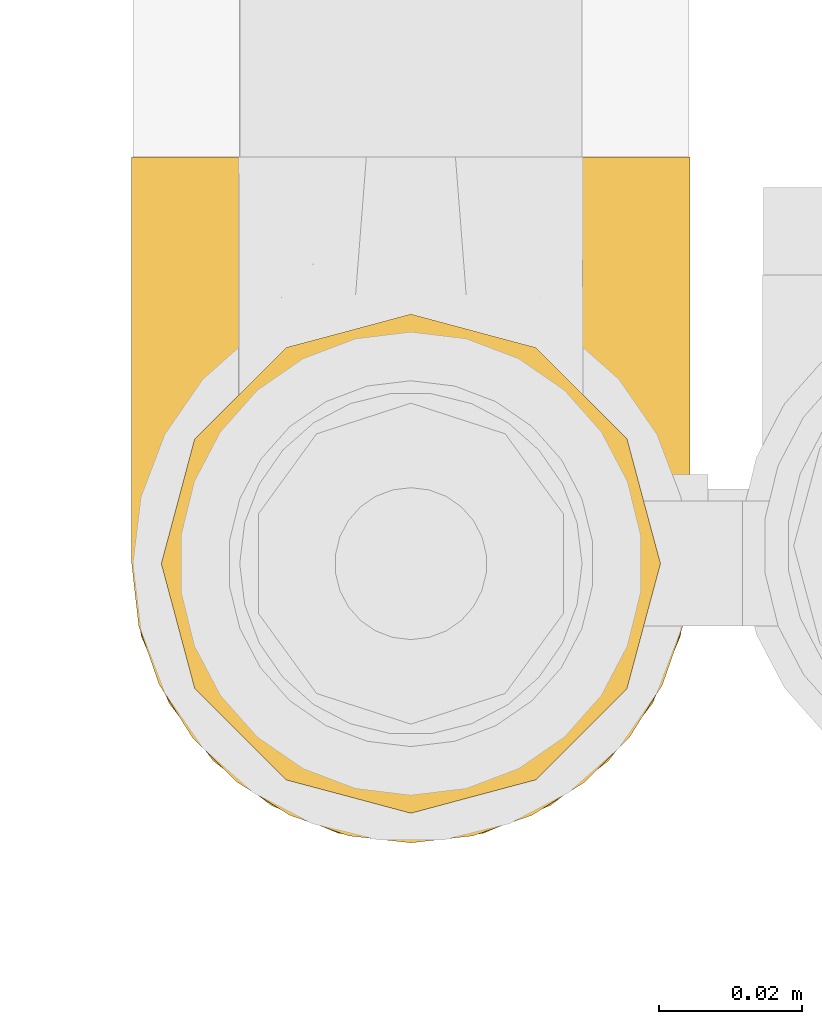
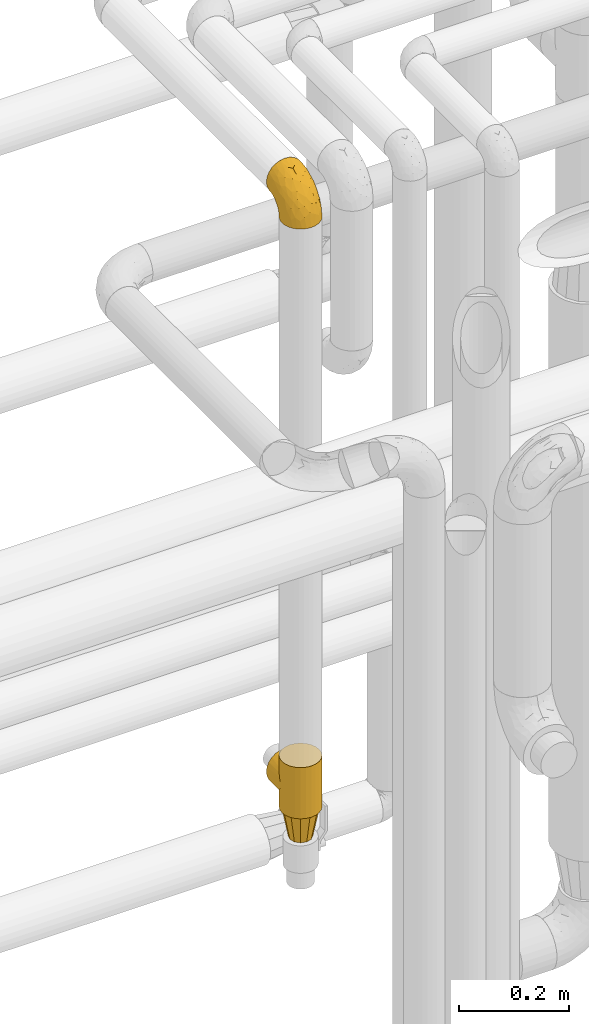
# One storey, part 428 of 827: 3 coverings.
"""IFC2X3 building model written with IfcOpenShell, lengths in millimetres."""

from ifc_helpers import new_model, entity, si_unit, converted_unit, derived_unit, direction, frame, origin, place, context, subcontext, project, spatial, faceted_brep, element, save


model = new_model("IFC2X3")

# Units and contexts
model_context = context("Model", 3, precision=0.01, world=origin(), true_north=direction((6.12303176911189e-17, 1.0)))
body_context = subcontext(model_context, "Body", "Model", "MODEL_VIEW")
ifc_project = project(units=[si_unit("LENGTHUNIT", "METRE", prefix="MILLI"), si_unit("AREAUNIT", "SQUARE_METRE"), si_unit("VOLUMEUNIT", "CUBIC_METRE"), converted_unit("PLANEANGLEUNIT", "DEGREE", entity("IfcRatioMeasure", 0.0174532925199433), si_unit("PLANEANGLEUNIT", "RADIAN"), dimensions=[0, 0, 0, 0, 0, 0, 0]), si_unit("MASSUNIT", "GRAM", prefix="KILO"), derived_unit("MASSDENSITYUNIT", [(si_unit("MASSUNIT", "GRAM", prefix="KILO"), 1), (si_unit("LENGTHUNIT", "METRE"), -3)]), derived_unit("MOMENTOFINERTIAUNIT", [(si_unit("LENGTHUNIT", "METRE"), 4)]), si_unit("TIMEUNIT", "SECOND"), si_unit("FREQUENCYUNIT", "HERTZ"), si_unit("THERMODYNAMICTEMPERATUREUNIT", "DEGREE_CELSIUS"), derived_unit("THERMALTRANSMITTANCEUNIT", [(si_unit("MASSUNIT", "GRAM", prefix="KILO"), 1), (si_unit("THERMODYNAMICTEMPERATUREUNIT", "KELVIN"), -1), (si_unit("TIMEUNIT", "SECOND"), -3)]), derived_unit("VOLUMETRICFLOWRATEUNIT", [(si_unit("LENGTHUNIT", "METRE"), 3), (si_unit("TIMEUNIT", "SECOND"), -1)]), derived_unit("MASSFLOWRATEUNIT", [(si_unit("MASSUNIT", "GRAM", prefix="KILO"), 1), (si_unit("TIMEUNIT", "SECOND"), -1)]), derived_unit("ROTATIONALFREQUENCYUNIT", [(si_unit("TIMEUNIT", "SECOND"), -1)]), si_unit("ELECTRICCURRENTUNIT", "AMPERE"), si_unit("ELECTRICVOLTAGEUNIT", "VOLT"), si_unit("POWERUNIT", "WATT"), si_unit("FORCEUNIT", "NEWTON", prefix="KILO"), si_unit("ILLUMINANCEUNIT", "LUX"), si_unit("LUMINOUSFLUXUNIT", "LUMEN"), si_unit("LUMINOUSINTENSITYUNIT", "CANDELA"), derived_unit("USERDEFINED", [(si_unit("MASSUNIT", "GRAM", prefix="KILO"), -1), (si_unit("LENGTHUNIT", "METRE"), -2), (si_unit("TIMEUNIT", "SECOND"), 3), (si_unit("LUMINOUSFLUXUNIT", "LUMEN"), 1)]), derived_unit("LINEARVELOCITYUNIT", [(si_unit("LENGTHUNIT", "METRE"), 1), (si_unit("TIMEUNIT", "SECOND"), -1)]), si_unit("PRESSUREUNIT", "PASCAL"), derived_unit("USERDEFINED", [(si_unit("LENGTHUNIT", "METRE"), -2), (si_unit("MASSUNIT", "GRAM", prefix="KILO"), 1), (si_unit("TIMEUNIT", "SECOND"), -2)]), derived_unit("LINEARFORCEUNIT", [(si_unit("MASSUNIT", "GRAM", prefix="KILO"), 1), (si_unit("LENGTHUNIT", "METRE"), 1), (si_unit("TIMEUNIT", "SECOND"), -2), (si_unit("LENGTHUNIT", "METRE"), -1)]), derived_unit("PLANARFORCEUNIT", [(si_unit("MASSUNIT", "GRAM", prefix="KILO"), 1), (si_unit("LENGTHUNIT", "METRE"), 1), (si_unit("TIMEUNIT", "SECOND"), -2), (si_unit("LENGTHUNIT", "METRE"), -2)])], contexts=[model_context])

# Site, building, storey
site_placement = place(None, origin())
site = spatial("IfcSite", under=ifc_project, at=site_placement, CompositionType="ELEMENT")
building_placement = place(site_placement, origin())
building = spatial("IfcBuilding", under=site, at=building_placement, CompositionType="ELEMENT")
storey_placement = place(building_placement, frame((0.0, 0.0, 28200.0)))
storey = spatial("IfcBuildingStorey", under=building, at=storey_placement, Name="08", CompositionType="ELEMENT", Elevation=28200.0)

# Coverings
covering_1_placement = place(storey_placement, frame((55693.43, 16227.19, 3141.4)))
element("IfcCovering", 1, at=covering_1_placement, inside=storey, Name=":ADSK_", ObjectType=":ADSK_", PredefinedType="INSULATION", context=body_context, shape_type="Brep", body=[
    faceted_brep([(79.9, 40.75, 1.6), (78.91, 32.03, 1.6), (76.02, 23.75, 1.6), (71.35, 16.33, 1.6), (65.15, 10.13, 1.6), (57.73, 5.47, 1.6), (49.45, 2.58, 1.6), (40.75, 1.6, 1.6), (32.03, 2.58, 1.6), (23.75, 5.48, 1.6), (16.33, 10.14, 1.6), (10.13, 16.34, 1.6), (5.47, 23.76, 1.6), (2.58, 32.04, 1.6), (1.6, 40.75, 1.6), (1.96, 43.94, 1.6), (2.58, 49.46, 1.6), (4.03, 53.6, 1.6), (5.48, 57.74, 1.6), (10.14, 65.16, 1.6), (16.34, 71.36, 1.6), (23.76, 76.02, 1.6), (32.04, 78.91, 1.6), (40.75, 79.9, 1.6), (49.46, 78.91, 1.6), (57.74, 76.02, 1.6), (65.16, 71.35, 1.6), (71.36, 65.15, 1.6), (76.02, 57.73, 1.6), (78.91, 49.45, 1.6), (79.54, 43.94, 1.6), (13.06, 97.75, 30.91), (6.84, 97.75, 39.02), (2.93, 97.75, 48.46), (2.44, 97.75, 52.18), (2.02, 97.75, 55.39), (1.6, 97.75, 58.6), (2.93, 97.75, 68.73), (6.84, 97.75, 78.17), (13.06, 97.75, 86.28), (21.17, 97.75, 92.5), (30.61, 97.75, 96.41), (40.75, 97.75, 97.75), (50.88, 97.75, 96.41), (60.32, 97.75, 92.5), (68.43, 97.75, 86.28), (74.65, 97.75, 78.17), (78.56, 97.75, 68.73), (79.9, 97.75, 58.6), (79.05, 97.75, 52.18), (78.56, 97.75, 48.46), (74.65, 97.75, 39.02), (68.43, 97.75, 30.91), (60.32, 97.75, 24.69), (50.88, 97.75, 20.78), (40.75, 97.75, 19.45), (30.61, 97.75, 20.78), (21.17, 97.75, 24.69), (40.75, 30.59, 68.75), (40.75, 19.96, 58.11), (53.99, 31.39, 67.95), (40.75, 41.23, 79.38), (40.75, 68.03, 93.04), (47.49, 73.86, 94.13), (40.75, 78.49, 94.7), (51.52, 51.06, 83.92), (61.86, 61.05, 83.74), (54.43, 74.96, 92.46), (63.37, 80.64, 88.89), (79.25, 35.94, 18.55), (77.04, 55.44, 59.47), (75.79, 78.19, 73.43), (72.61, 58.08, 70.77), (78.93, 78.4, 64.34), (70.12, 74.65, 81.19), (66.7, 14.61, 24.77), (72.7, 20.05, 18.96), (70.21, 24.25, 39.69), (78.8, 43.81, 39.98), (79.9, 45.08, 23.41), (79.9, 48.17, 28.03), (79.9, 51.26, 32.65), (79.9, 54.35, 37.28), (79.9, 57.44, 41.9), (74.44, 40.25, 52.71), (52.47, 6.22, 24.51), (79.33, 61.23, 53.67), (79.9, 62.06, 44.99), (79.9, 66.69, 48.08), (79.9, 71.31, 51.17), (79.9, 75.93, 54.26), (48.94, 13.08, 45.31), (58.78, 14.98, 41.19), (60.43, 8.5, 18.54), (40.75, 4.64, 20.85), (62.02, 36.67, 67.52), (57.53, 22.97, 55.82), (79.9, 41.46, 5.17), (79.9, 42.17, 8.74), (79.9, 43.59, 15.88), (64.12, 25.24, 52.18), (75.76, 31.25, 35.23), (76.65, 26.96, 17.8), (68.92, 38.0, 60.91), (66.73, 50.65, 73.89), (40.75, 54.63, 86.21), (40.75, 6.3, 31.31), (79.9, 83.46, 55.75), (79.9, 87.03, 56.46), (79.9, 90.6, 57.17), (40.75, 13.13, 44.71), (63.86, 91.79, 26.29), (69.15, 87.2, 29.74), (78.65, 87.5, 47.68), (72.98, 89.79, 35.46), (76.47, 88.45, 41.52), (76.82, 81.77, 40.21), (79.05, 79.81, 47.09), (79.09, 73.84, 44.48), (51.28, 91.84, 19.96), (51.03, 86.62, 17.27), (40.75, 85.12, 14.22), (40.75, 91.15, 16.71), (49.93, 80.84, 10.14), (58.53, 78.96, 13.28), (69.86, 71.38, 17.56), (65.19, 76.81, 17.71), (70.75, 74.29, 23.15), (79.25, 48.29, 8.48), (79.11, 49.97, 13.45), (57.89, 92.85, 22.84), (55.93, 77.55, 7.02), (78.06, 62.05, 29.23), (75.39, 70.85, 29.51), (78.16, 65.52, 33.67), (66.62, 80.71, 23.34), (73.14, 77.97, 30.5), (71.07, 66.14, 7.97), (78.32, 57.01, 22.97), (73.93, 64.57, 16.17), (77.25, 56.53, 13.36), (79.26, 51.07, 19.39), (60.3, 81.85, 18.33), (40.75, 82.63, 8.19), (65.72, 72.53, 10.82), (74.5, 67.69, 23.48), (60.62, 86.44, 21.93), (73.96, 82.44, 34.48), (77.3, 75.97, 38.65), (77.83, 70.39, 36.64), (23.6, 92.85, 22.84), (17.57, 88.99, 25.49), (1.6, 41.46, 5.17), (1.6, 42.17, 8.74), (1.6, 43.59, 15.88), (31.57, 80.84, 10.14), (22.97, 78.97, 13.28), (25.57, 77.55, 7.02), (15.78, 72.54, 10.82), (1.6, 83.46, 55.75), (1.6, 90.6, 57.17), (1.6, 94.17, 57.88), (12.34, 87.2, 29.74), (7.57, 82.6, 34.5), (8.85, 89.34, 34.84), (2.63, 80.74, 46.53), (4.67, 81.77, 40.21), (2.36, 74.04, 44.84), (1.6, 75.93, 54.26), (2.84, 87.5, 47.68), (2.24, 51.07, 19.39), (1.6, 48.17, 28.03), (3.18, 57.03, 22.96), (10.74, 74.31, 23.16), (15.18, 80.61, 22.9), (16.42, 77.09, 17.91), (30.21, 91.84, 19.96), (9.98, 79.19, 28.63), (30.46, 86.62, 17.27), (10.43, 66.15, 7.97), (12.05, 71.84, 17.45), (4.24, 56.55, 13.36), (7.56, 64.59, 16.17), (3.43, 62.05, 29.23), (2.38, 49.99, 13.44), (1.6, 45.08, 23.41), (3.66, 70.39, 36.64), (4.45, 76.36, 38.11), (6.98, 67.71, 23.51), (6.12, 70.92, 29.52), (5.38, 89.33, 40.9), (21.58, 82.04, 18.21), (1.6, 51.26, 32.65), (20.87, 86.44, 21.93), (3.35, 65.56, 33.63), (1.6, 62.06, 44.99), (1.6, 57.44, 41.9), (1.6, 54.35, 37.28), (1.6, 71.31, 51.17), (1.6, 66.69, 48.08), (2.16, 61.23, 53.67), (11.37, 74.65, 81.19), (5.7, 78.19, 73.43), (8.88, 58.07, 70.76), (12.57, 38.01, 60.91), (7.04, 40.25, 52.7), (11.27, 24.26, 39.68), (17.36, 25.25, 52.18), (2.69, 43.81, 39.98), (2.56, 78.4, 64.34), (34.0, 73.86, 94.13), (27.06, 74.96, 92.46), (4.45, 55.45, 59.46), (5.73, 31.26, 35.22), (18.12, 80.64, 88.89), (19.63, 61.05, 83.74), (27.49, 31.39, 67.95), (19.46, 36.69, 67.52), (2.24, 35.95, 18.55), (29.01, 6.22, 24.51), (14.78, 14.62, 24.77), (32.55, 13.09, 45.32), (8.78, 20.06, 18.96), (29.98, 51.06, 83.92), (23.95, 22.97, 55.82), (22.7, 14.99, 41.19), (21.05, 8.51, 18.54), (14.75, 50.64, 73.87), (4.84, 26.97, 17.8)], [[[0, 1, 2, 3, 4, 5, 6, 7, 8, 9, 10, 11, 12, 13, 14, 15, 16, 17, 18, 19, 20, 21, 22, 23, 24, 25, 26, 27, 28, 29, 30]], [[31, 32, 33, 34, 35, 36, 37, 38, 39, 40, 41, 42, 43, 44, 45, 46, 47, 48, 49, 50, 51, 52, 53, 54, 55, 56, 57]], [[58, 59, 60, 61]], [[62, 63, 64]], [[65, 66, 67]], [[67, 66, 68]], [[69, 1, 0]], [[70, 71, 72]], [[44, 43, 67]], [[47, 71, 73]], [[45, 74, 46]], [[68, 45, 44]], [[75, 76, 77]], [[76, 3, 2]], [[78, 79, 80, 81, 82, 83]], [[48, 47, 73]], [[70, 72, 84]], [[5, 85, 6]], [[86, 83, 87, 88, 89, 90]], [[91, 85, 92]], [[76, 75, 3]], [[71, 46, 74]], [[85, 5, 93]], [[45, 68, 74]], [[5, 4, 93]], [[85, 94, 6]], [[86, 78, 83]], [[60, 95, 65]], [[96, 95, 60]], [[75, 4, 3]], [[69, 0, 97, 98, 99, 79]], [[75, 77, 100]], [[43, 64, 63]], [[101, 102, 69]], [[101, 76, 102]], [[46, 71, 47]], [[95, 103, 104]], [[92, 85, 93]], [[63, 105, 65]], [[92, 75, 100]], [[91, 106, 85]], [[84, 78, 70]], [[67, 68, 44]], [[65, 67, 63]], [[65, 61, 60]], [[4, 75, 93]], [[92, 93, 75]], [[102, 76, 2]], [[77, 76, 101]], [[84, 77, 101]], [[77, 103, 100]], [[72, 71, 74]], [[70, 86, 73]], [[104, 74, 66]], [[84, 72, 103]], [[70, 73, 71]], [[73, 90, 107, 108, 109, 48]], [[79, 78, 69]], [[101, 69, 78]], [[91, 92, 96]], [[91, 59, 110, 106]], [[2, 1, 102]], [[69, 102, 1]], [[94, 85, 106]], [[94, 7, 6]], [[74, 68, 66]], [[43, 42, 64]], [[43, 63, 67]], [[73, 86, 90]], [[78, 86, 70]], [[95, 100, 103]], [[96, 92, 100]], [[104, 103, 72]], [[65, 95, 66]], [[74, 104, 72]], [[66, 95, 104]], [[95, 96, 100]], [[91, 96, 60]], [[77, 84, 103]], [[78, 84, 101]], [[60, 59, 91]], [[105, 63, 62]], [[105, 61, 65]], [[111, 52, 112]], [[107, 90, 113]], [[114, 115, 116]], [[50, 107, 113]], [[117, 118, 116]], [[54, 119, 55]], [[97, 0, 30, 29, 98]], [[113, 115, 51]], [[120, 121, 122]], [[123, 120, 124]], [[125, 126, 127]], [[128, 28, 129]], [[130, 54, 53]], [[25, 24, 131]], [[132, 133, 134]], [[135, 112, 136]], [[137, 27, 26]], [[121, 120, 123]], [[138, 139, 132]], [[129, 140, 141]], [[135, 126, 142]], [[27, 140, 28]], [[27, 137, 140]], [[49, 48, 109, 108, 107, 50]], [[23, 143, 121, 123]], [[25, 131, 144]], [[26, 25, 144]], [[128, 98, 29]], [[125, 127, 145]], [[146, 130, 111]], [[137, 144, 139]], [[139, 138, 140]], [[116, 147, 114]], [[123, 124, 131]], [[116, 118, 148]], [[134, 83, 82]], [[129, 79, 99]], [[54, 130, 119]], [[141, 79, 129]], [[122, 55, 119]], [[120, 146, 142]], [[117, 113, 90]], [[50, 113, 51]], [[127, 133, 145]], [[147, 136, 112]], [[136, 133, 127]], [[24, 23, 123]], [[118, 117, 89]], [[149, 87, 134]], [[144, 131, 124]], [[24, 123, 131]], [[128, 129, 99]], [[28, 140, 129]], [[144, 137, 26]], [[140, 137, 139]], [[81, 138, 132]], [[138, 80, 141]], [[89, 88, 87, 118]], [[115, 117, 116]], [[140, 138, 141]], [[148, 118, 149]], [[136, 148, 149]], [[147, 116, 148]], [[133, 136, 149]], [[127, 126, 135]], [[136, 147, 148]], [[114, 112, 52]], [[112, 114, 147]], [[51, 114, 52]], [[51, 115, 114]], [[117, 115, 113]], [[117, 90, 89]], [[134, 133, 149]], [[145, 133, 132]], [[132, 139, 145]], [[125, 139, 144]], [[139, 125, 145]], [[126, 144, 124]], [[144, 126, 125]], [[142, 126, 124]], [[120, 142, 124]], [[142, 146, 135]], [[112, 135, 146]], [[136, 127, 135]], [[118, 87, 149]], [[82, 81, 132]], [[111, 130, 53]], [[119, 146, 120]], [[146, 119, 130]], [[122, 119, 120]], [[52, 111, 53]], [[146, 111, 112]], [[134, 82, 132]], [[83, 134, 87]], [[98, 128, 99]], [[80, 138, 81]], [[80, 79, 141]], [[28, 128, 29]], [[150, 151, 57]], [[15, 14, 152, 153, 154, 16]], [[121, 143, 23, 155]], [[150, 57, 56]], [[156, 157, 158]], [[35, 34, 33, 159, 160, 161, 36]], [[162, 31, 57]], [[163, 164, 162]], [[165, 166, 167]], [[155, 23, 22]], [[168, 159, 169]], [[170, 171, 172]], [[173, 174, 175]], [[55, 122, 176]], [[177, 174, 173]], [[22, 157, 155]], [[178, 121, 155]], [[169, 33, 32]], [[20, 19, 179]], [[21, 20, 158]], [[158, 180, 175]], [[181, 182, 179]], [[172, 183, 182]], [[122, 121, 178]], [[181, 19, 18]], [[184, 185, 170]], [[17, 154, 184]], [[186, 187, 177]], [[187, 186, 167]], [[179, 158, 20]], [[21, 157, 22]], [[175, 180, 173]], [[188, 189, 173]], [[164, 166, 190]], [[185, 184, 154]], [[181, 172, 182]], [[156, 191, 178]], [[192, 183, 172]], [[178, 176, 122]], [[193, 150, 176]], [[33, 169, 159]], [[190, 169, 32]], [[189, 194, 186]], [[180, 188, 173]], [[167, 166, 187]], [[166, 164, 163]], [[195, 194, 196]], [[158, 157, 21]], [[155, 157, 156]], [[178, 155, 156]], [[181, 18, 184]], [[17, 16, 154]], [[181, 179, 19]], [[158, 179, 182]], [[170, 181, 184]], [[196, 194, 197]], [[31, 190, 32]], [[165, 190, 166]], [[190, 31, 164]], [[31, 162, 164]], [[177, 163, 162]], [[187, 166, 163]], [[151, 174, 177]], [[177, 173, 189]], [[177, 187, 163]], [[195, 167, 186]], [[165, 198, 168]], [[165, 168, 169]], [[167, 198, 165]], [[190, 165, 169]], [[167, 195, 199, 198]], [[151, 177, 162]], [[175, 191, 156]], [[191, 174, 193]], [[158, 175, 156]], [[174, 191, 175]], [[178, 191, 193]], [[158, 182, 180]], [[188, 182, 183]], [[182, 188, 180]], [[183, 194, 189]], [[183, 189, 188]], [[177, 189, 186]], [[194, 183, 197]], [[176, 150, 56]], [[151, 150, 193]], [[176, 56, 55]], [[193, 176, 178]], [[174, 151, 193]], [[57, 151, 162]], [[183, 192, 197]], [[194, 195, 186]], [[171, 192, 172]], [[172, 181, 170]], [[170, 185, 171]], [[184, 18, 17]], [[200, 168, 198, 199, 195, 196]], [[201, 202, 203]], [[204, 203, 205]], [[204, 206, 207]], [[208, 196, 197, 192, 171, 185]], [[209, 36, 161, 160, 159, 168]], [[202, 38, 37]], [[201, 38, 202]], [[210, 41, 211]], [[200, 208, 212]], [[205, 208, 213]], [[214, 211, 40]], [[40, 211, 41]], [[214, 201, 215]], [[58, 61, 216, 59]], [[201, 39, 38]], [[207, 217, 204]], [[213, 208, 218]], [[218, 185, 154, 153, 152, 14]], [[14, 13, 218]], [[9, 8, 219]], [[10, 220, 11]], [[221, 106, 110, 59]], [[219, 8, 94]], [[220, 222, 11]], [[223, 211, 215]], [[221, 216, 224]], [[225, 219, 221]], [[10, 9, 226]], [[213, 222, 206]], [[226, 9, 219]], [[106, 219, 94]], [[212, 202, 209]], [[201, 203, 227]], [[226, 225, 220]], [[207, 206, 220]], [[214, 40, 39]], [[11, 222, 12]], [[12, 222, 228]], [[41, 210, 64]], [[223, 105, 210]], [[223, 215, 217]], [[105, 62, 210]], [[206, 222, 220]], [[228, 222, 213]], [[207, 220, 225]], [[205, 206, 204]], [[225, 226, 219]], [[220, 10, 226]], [[209, 202, 37]], [[203, 202, 212]], [[205, 203, 212]], [[204, 217, 227]], [[36, 209, 37]], [[209, 168, 200]], [[218, 13, 228]], [[208, 185, 218]], [[106, 221, 219]], [[221, 59, 216]], [[218, 228, 213]], [[13, 12, 228]], [[8, 7, 94]], [[201, 214, 39]], [[211, 214, 215]], [[64, 210, 62]], [[64, 42, 41]], [[223, 210, 211]], [[208, 200, 196]], [[209, 200, 212]], [[225, 224, 207]], [[207, 224, 217]], [[223, 217, 216]], [[204, 227, 203]], [[217, 215, 227]], [[201, 227, 215]], [[221, 224, 225]], [[217, 224, 216]], [[208, 205, 212]], [[206, 205, 213]], [[216, 61, 223]], [[223, 61, 105]]]),
])
covering_2_placement = place(storey_placement, frame((55693.43, 16227.19, 1830.16)))
element("IfcCovering", 2, at=covering_2_placement, inside=storey, Name=":ADSK_", ObjectType=":ADSK_", PredefinedType="INSULATION", context=body_context, shape_type="Brep", body=[
    faceted_brep([(79.46, 46.6, 51.15), (79.9, 40.75, 0.0), (78.56, 50.88, 0.0), (74.65, 60.32, 0.0), (75.87, 58.03, 39.72), (72.65, 63.43, 34.31), (68.43, 68.43, 0.0), (79.9, 40.75, 57.0), (79.46, 46.6, 62.85), (79.9, 40.75, 114.0), (78.13, 52.38, 45.36), (63.01, 72.95, 24.8), (60.32, 74.65, 0.0), (56.49, 76.59, 21.16), (50.88, 78.56, 0.0), (48.95, 79.03, 18.72), (40.75, 79.9, 0.0), (68.39, 68.47, 29.28), (40.75, 79.9, 17.85), (40.75, 79.9, 114.0), (48.95, 79.03, 95.28), (40.75, 79.9, 96.15), (31.55, 78.8, 18.95), (30.61, 78.56, 0.0), (23.26, 75.77, 21.97), (21.17, 74.65, 0.0), (16.33, 71.35, 26.4), (13.06, 68.43, 0.0), (31.55, 78.8, 95.05), (10.84, 66.01, 31.73), (6.71, 60.09, 37.65), (6.84, 60.32, 0.0), (3.84, 53.82, 43.93), (2.93, 50.88, 0.0), (2.15, 47.33, 50.42), (1.6, 40.75, 0.0), (1.6, 40.75, 57.0), (2.15, 47.33, 63.58), (1.6, 40.75, 114.0), (21.17, 6.84, 114.0), (30.61, 2.93, 114.0), (40.75, 1.6, 114.0), (50.88, 2.93, 114.0), (60.32, 6.84, 114.0), (68.43, 13.06, 114.0), (74.65, 21.17, 114.0), (78.56, 30.61, 114.0), (78.56, 50.88, 114.0), (74.65, 60.32, 114.0), (68.43, 68.43, 114.0), (60.32, 74.65, 114.0), (50.88, 78.56, 114.0), (30.61, 78.56, 114.0), (21.17, 74.65, 114.0), (13.06, 68.43, 114.0), (6.84, 60.32, 114.0), (2.93, 50.88, 114.0), (2.93, 30.61, 114.0), (6.84, 21.17, 114.0), (13.06, 13.06, 114.0), (78.56, 30.61, 0.0), (74.65, 21.17, 0.0), (68.43, 13.06, 0.0), (60.32, 6.84, 0.0), (50.88, 2.93, 0.0), (40.75, 1.6, 0.0), (30.61, 2.93, 0.0), (21.17, 6.84, 0.0), (13.06, 13.06, 0.0), (6.84, 21.17, 0.0), (2.93, 30.61, 0.0), (78.13, 52.38, 68.64), (75.87, 58.03, 74.28), (72.65, 63.43, 79.69), (68.39, 68.47, 84.72), (63.01, 72.95, 89.2), (56.49, 76.59, 92.84), (23.26, 75.77, 92.03), (16.33, 71.35, 87.6), (10.84, 66.01, 82.27), (6.71, 60.09, 76.35), (3.84, 53.82, 70.07), (78.56, 97.75, 67.13), (79.9, 97.75, 57.0), (78.56, 97.75, 46.87), (74.65, 97.75, 37.42), (68.43, 97.75, 29.32), (60.32, 97.75, 23.1), (50.88, 97.75, 19.18), (40.75, 97.75, 17.85), (30.61, 97.75, 19.18), (21.17, 97.75, 23.1), (13.06, 97.75, 29.32), (6.84, 97.75, 37.42), (2.93, 97.75, 46.87), (1.6, 97.75, 57.0), (2.93, 97.75, 67.13), (6.84, 97.75, 76.57), (13.06, 97.75, 84.68), (21.17, 97.75, 90.9), (30.61, 97.75, 94.82), (40.75, 97.75, 96.15), (50.88, 97.75, 94.82), (60.32, 97.75, 90.9), (68.43, 97.75, 84.68), (74.65, 97.75, 76.57)], [[[0, 1, 2]], [[2, 3, 4]], [[5, 3, 6]], [[5, 4, 3]], [[0, 7, 1]], [[7, 8, 9]], [[4, 10, 2]], [[0, 2, 10]], [[11, 6, 12]], [[13, 12, 14]], [[15, 14, 16]], [[11, 17, 6]], [[15, 13, 14]], [[18, 15, 16]], [[19, 20, 21]], [[11, 12, 13]], [[6, 17, 5]], [[22, 16, 23]], [[24, 23, 25]], [[26, 25, 27]], [[22, 18, 16]], [[21, 28, 19]], [[26, 24, 25]], [[22, 23, 24]], [[27, 29, 26]], [[30, 29, 31]], [[31, 29, 27]], [[32, 31, 33]], [[34, 33, 35]], [[32, 30, 31]], [[36, 34, 35]], [[37, 36, 38]], [[32, 33, 34]], [[39, 40, 41, 42, 43, 44, 45, 46, 9, 47, 48, 49, 50, 51, 19, 52, 53, 54, 55, 56, 38, 57, 58, 59]], [[2, 1, 60, 61, 62, 63, 64, 65, 66, 67, 68, 69, 70, 35, 33, 31, 27, 25, 23, 16, 14, 12, 6, 3]], [[63, 62, 44, 43]], [[42, 41, 65, 64]], [[64, 63, 43, 42]], [[45, 61, 60, 46]], [[1, 7, 9, 46, 60]], [[44, 62, 61, 45]], [[71, 72, 47]], [[8, 71, 47]], [[9, 8, 47]], [[48, 73, 49]], [[48, 47, 72]], [[73, 48, 72]], [[74, 75, 49]], [[76, 20, 51]], [[75, 76, 50]], [[49, 75, 50]], [[20, 19, 51]], [[51, 50, 76]], [[74, 49, 73]], [[77, 78, 53]], [[28, 77, 52]], [[19, 28, 52]], [[52, 77, 53]], [[78, 54, 53]], [[78, 79, 54]], [[80, 81, 55]], [[81, 37, 56]], [[79, 55, 54]], [[79, 80, 55]], [[55, 81, 56]], [[37, 38, 56]], [[36, 35, 70, 57, 38]], [[57, 70, 69, 58]], [[69, 68, 59, 58]], [[59, 68, 67, 39]], [[39, 67, 66, 40]], [[40, 66, 65, 41]], [[82, 83, 84, 85, 86, 87, 88, 89, 90, 91, 92, 93, 94, 95, 96, 97, 98, 99, 100, 101, 102, 103, 104, 105]], [[15, 18, 89]], [[15, 89, 88]], [[13, 88, 87]], [[13, 15, 88]], [[86, 17, 11]], [[13, 87, 11]], [[11, 87, 86]], [[5, 86, 85]], [[4, 85, 84]], [[0, 84, 83]], [[4, 5, 85]], [[0, 10, 84]], [[7, 0, 83]], [[4, 84, 10]], [[86, 5, 17]], [[8, 83, 82]], [[82, 105, 72]], [[73, 105, 104]], [[73, 72, 105]], [[8, 7, 83]], [[72, 71, 82]], [[8, 82, 71]], [[75, 104, 103]], [[76, 103, 102]], [[20, 102, 101]], [[75, 74, 104]], [[20, 76, 102]], [[21, 20, 101]], [[75, 103, 76]], [[104, 74, 73]], [[28, 101, 100]], [[77, 100, 99]], [[78, 99, 98]], [[28, 21, 101]], [[78, 77, 99]], [[28, 100, 77]], [[98, 79, 78]], [[80, 79, 97]], [[97, 79, 98]], [[81, 97, 96]], [[37, 96, 95]], [[81, 80, 97]], [[36, 37, 95]], [[81, 96, 37]], [[34, 95, 94]], [[94, 93, 32]], [[29, 93, 92]], [[29, 30, 93]], [[34, 36, 95]], [[30, 32, 93]], [[34, 94, 32]], [[26, 92, 91]], [[24, 91, 90]], [[22, 90, 89]], [[24, 26, 91]], [[18, 22, 89]], [[24, 90, 22]], [[92, 26, 29]]]),
])
covering_3_placement = place(storey_placement, frame((55697.58, 16231.34, 1765.16)))
element("IfcCovering", 3, at=covering_3_placement, inside=storey, Name=":ADSK_", ObjectType=":ADSK_", PredefinedType="INSULATION", context=body_context, shape_type="Brep", body=[
    faceted_brep([(60.5, 60.5, 65.0), (54.1, 66.91, 65.0), (44.85, 69.38, 65.0), (36.6, 71.6, 65.0), (28.35, 69.38, 65.0), (19.1, 66.91, 65.0), (12.69, 60.5, 65.0), (6.28, 54.1, 65.0), (3.81, 44.85, 65.0), (1.6, 36.6, 65.0), (3.81, 28.35, 65.0), (6.28, 19.1, 65.0), (12.69, 12.69, 65.0), (19.1, 6.28, 65.0), (28.35, 3.81, 65.0), (36.6, 1.6, 65.0), (44.85, 3.81, 65.0), (54.1, 6.28, 65.0), (60.5, 12.69, 65.0), (66.91, 19.1, 65.0), (69.38, 28.35, 65.0), (71.6, 36.6, 65.0), (69.38, 44.85, 65.0), (66.91, 54.1, 65.0), (56.08, 25.35, 0.0), (51.96, 21.23, 0.0), (47.85, 17.11, 0.0), (42.22, 15.6, 0.0), (36.6, 14.1, 0.0), (30.97, 15.6, 0.0), (25.35, 17.11, 0.0), (21.23, 21.23, 0.0), (17.11, 25.35, 0.0), (15.6, 30.97, 0.0), (14.1, 36.6, 0.0), (15.6, 42.22, 0.0), (17.11, 47.85, 0.0), (21.23, 51.96, 0.0), (25.35, 56.08, 0.0), (30.97, 57.59, 0.0), (36.6, 59.1, 0.0), (42.22, 57.59, 0.0), (47.85, 56.08, 0.0), (51.96, 51.96, 0.0), (56.08, 47.85, 0.0), (57.59, 42.22, 0.0), (59.1, 36.6, 0.0), (57.59, 30.97, 0.0)], [[[0, 1, 2, 3, 4, 5, 6, 7, 8, 9, 10, 11, 12, 13, 14, 15, 16, 17, 18, 19, 20, 21, 22, 23]], [[24, 25, 26, 27, 28, 29, 30, 31, 32, 33, 34, 35, 36, 37, 38, 39, 40, 41, 42, 43, 44, 45, 46, 47]], [[5, 4, 3, 40, 39, 38]], [[6, 5, 38, 37, 36, 7]], [[8, 7, 36, 35, 34, 9]], [[11, 10, 9, 34, 33, 32]], [[12, 11, 32, 31, 30, 13]], [[14, 13, 30, 29, 28, 15]], [[17, 16, 15, 28, 27, 26]], [[18, 17, 26, 25, 24, 19]], [[20, 19, 24, 47, 46, 21]], [[23, 22, 21, 46, 45, 44]], [[0, 23, 44, 43, 42, 1]], [[2, 1, 42, 41, 40, 3]]]),
])

save(model, "model.ifc")
